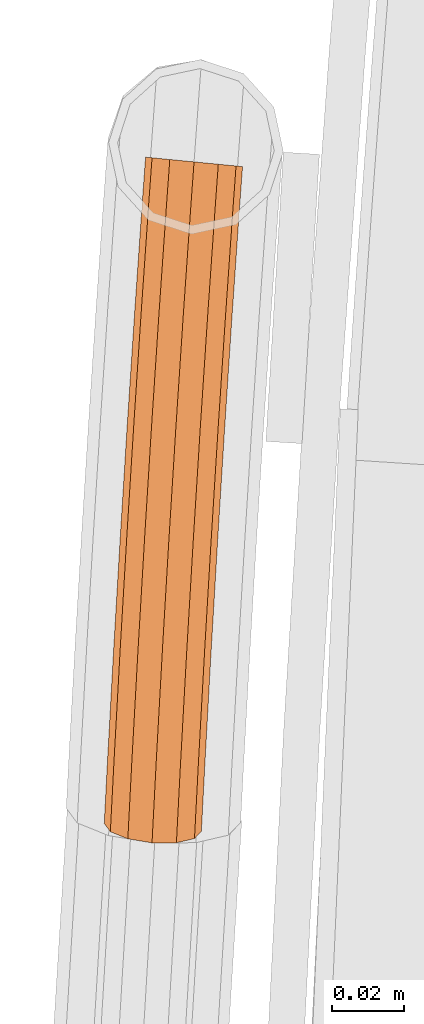
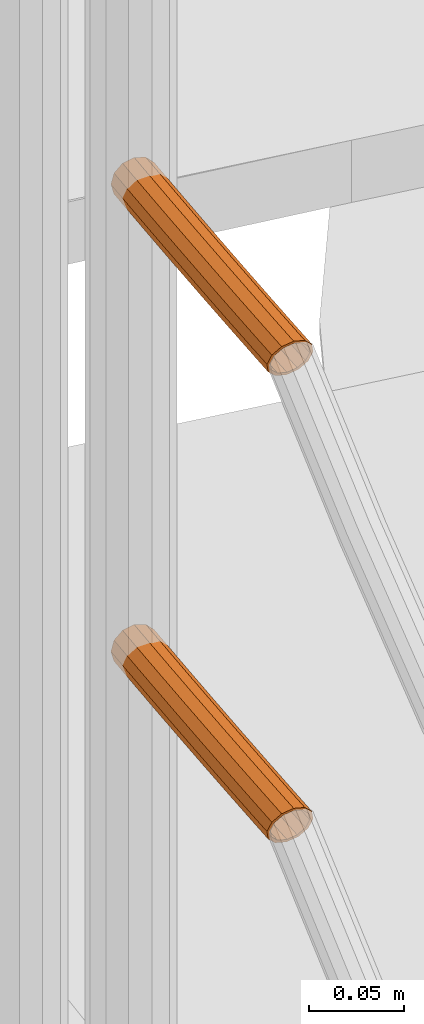
# One storey, part 57 of 126: 2 proxies.
"""IFC2X3 building model written with IfcOpenShell, lengths in millimetres."""

from ifc_helpers import new_model, si_unit, origin, origin_with_axes, place, context, project, spatial, faceted_brep, material, element, save


model = new_model("IFC2X3")

# Units and contexts
context_of_model_1 = context(None, 3, precision=0.1, world=origin())
context_of_model_2 = context(None, 3, precision=0.1, world=origin())
ifc_project = project(units=[si_unit("LENGTHUNIT", "METRE", prefix="MILLI"), si_unit("AREAUNIT", "SQUARE_METRE", prefix="CENTI"), si_unit("VOLUMEUNIT", "CUBIC_METRE", prefix="CENTI"), si_unit("MASSUNIT", "GRAM", prefix="KILO")], contexts=[context_of_model_1, context_of_model_2])

# Site, building, storey
site_placement = place(None, origin_with_axes())
site = spatial("IfcSite", under=ifc_project, at=site_placement, CompositionType="ELEMENT")
building_placement = place(site_placement, origin_with_axes())
building = spatial("IfcBuilding", under=site, at=building_placement, CompositionType="ELEMENT")
storey_placement = place(building_placement, origin_with_axes())
storey = spatial("IfcBuildingStorey", under=building, at=storey_placement, CompositionType="ELEMENT")

# Proxies
ifc_material = material(Name="S235JRG2")
proxy_1_placement = place(storey_placement, origin_with_axes())
element("IfcBuildingElementProxy", 1, at=proxy_1_placement, inside=storey, material=ifc_material, context=context_of_model_2, shape_type="Brep", body=[
    faceted_brep([(-848.952, 8648.8633, 6295.5551), (-848.1038, 8660.504, 6295.5551), (-846.3098, 8660.3291, 6288.8301), (-847.1546, 8648.7355, 6288.8301), (-841.4085, 8659.8513, 6283.907), (-842.2439, 8648.3862, 6283.907), (-834.7132, 8659.1987, 6282.1051), (-835.5359, 8647.9092, 6282.1051), (-828.018, 8658.546, 6283.907), (-828.8278, 8647.4322, 6283.907), (-823.1167, 8658.0682, 6288.8301), (-823.9172, 8647.083, 6288.8301), (-821.3227, 8657.8933, 6295.5551), (-822.1197, 8646.9551, 6295.5551), (-823.1167, 8658.0682, 6302.2801), (-823.9172, 8647.083, 6302.2801), (-828.018, 8658.546, 6307.2031), (-828.8278, 8647.4322, 6307.2031), (-834.7132, 8659.1987, 6309.0051), (-835.5359, 8647.9092, 6309.0051), (-841.4085, 8659.8513, 6307.2031), (-842.2439, 8648.3862, 6307.2031), (-846.3098, 8660.3291, 6302.2801), (-847.1546, 8648.7355, 6302.2801), (-846.957, 8648.7214, 6295.5551), (-846.1126, 8660.3099, 6295.5551), (-844.5854, 8660.161, 6301.2801), (-845.4269, 8648.6126, 6301.2801), (-840.4129, 8659.7543, 6305.4711), (-841.2465, 8648.3153, 6305.4711), (-834.7132, 8659.1987, 6307.0051), (-835.5359, 8647.9092, 6307.0051), (-829.0135, 8658.6431, 6305.4711), (-829.8253, 8647.5031, 6305.4711), (-824.8411, 8658.2363, 6301.2801), (-825.6448, 8647.2058, 6301.2801), (-823.3138, 8658.0874, 6295.5551), (-824.1147, 8647.097, 6295.5551), (-824.8411, 8658.2363, 6289.8301), (-825.6448, 8647.2058, 6289.8301), (-829.0135, 8658.6431, 6285.6391), (-829.8253, 8647.5031, 6285.6391), (-834.7132, 8659.1987, 6284.1051), (-835.5359, 8647.9092, 6284.1051), (-840.4129, 8659.7543, 6285.6391), (-841.2465, 8648.3153, 6285.6391), (-844.5854, 8660.161, 6289.8301), (-845.4269, 8648.6126, 6289.8301), (-849.2983, 8617.8278, 6288.8301), (-851.0962, 8617.9494, 6295.5551), (-844.3865, 8617.4958, 6283.907), (-837.6768, 8617.0421, 6282.1051), (-830.9671, 8616.5885, 6283.907), (-826.0553, 8616.2565, 6288.8301), (-824.2574, 8616.1349, 6295.5551), (-826.0553, 8616.2565, 6302.2801), (-830.9671, 8616.5885, 6307.2031), (-837.6768, 8617.0421, 6309.0051), (-844.3865, 8617.4958, 6307.2031), (-849.2983, 8617.8278, 6302.2801), (-847.5702, 8617.711, 6301.2801), (-849.1007, 8617.8145, 6295.5551), (-843.3888, 8617.4283, 6305.4711), (-837.6768, 8617.0421, 6307.0051), (-831.9648, 8616.656, 6305.4711), (-827.7834, 8616.3733, 6301.2801), (-826.2529, 8616.2698, 6295.5551), (-827.7834, 8616.3733, 6289.8301), (-831.9648, 8616.656, 6285.6391), (-837.6768, 8617.0421, 6284.1051), (-843.3888, 8617.4283, 6285.6391), (-847.5702, 8617.711, 6289.8301), (-851.3342, 8586.9129, 6288.8301), (-853.1324, 8587.0282, 6295.5551), (-846.4212, 8586.598, 6283.907), (-839.71, 8586.1678, 6282.1051), (-832.9987, 8585.7376, 6283.907), (-828.0858, 8585.4227, 6288.8301), (-826.2875, 8585.3074, 6295.5551), (-828.0858, 8585.4227, 6302.2801), (-832.9987, 8585.7376, 6307.2031), (-839.71, 8586.1678, 6309.0051), (-846.4212, 8586.598, 6307.2031), (-851.3342, 8586.9129, 6302.2801), (-849.6057, 8586.8021, 6301.2801), (-851.1365, 8586.9002, 6295.5551), (-845.4233, 8586.534, 6305.4711), (-839.71, 8586.1678, 6307.0051), (-833.9967, 8585.8016, 6305.4711), (-829.8143, 8585.5335, 6301.2801), (-828.2834, 8585.4353, 6295.5551), (-829.8143, 8585.5335, 6289.8301), (-833.9967, 8585.8016, 6285.6391), (-839.71, 8586.1678, 6284.1051), (-845.4233, 8586.534, 6285.6391), (-849.6057, 8586.8021, 6289.8301), (-853.2621, 8555.9911, 6288.8301), (-855.0607, 8556.1, 6295.5551), (-848.3481, 8555.6933, 6283.907), (-841.6354, 8555.2865, 6282.1051), (-834.9227, 8554.8798, 6283.907), (-830.0086, 8554.582, 6288.8301), (-828.21, 8554.473, 6295.5551), (-830.0086, 8554.582, 6302.2801), (-834.9227, 8554.8798, 6307.2031), (-841.6354, 8555.2865, 6309.0051), (-848.3481, 8555.6933, 6307.2031), (-853.2621, 8555.9911, 6302.2801), (-851.5332, 8555.8863, 6301.2801), (-853.0644, 8555.9791, 6295.5551), (-847.3499, 8555.6328, 6305.4711), (-841.6354, 8555.2865, 6307.0051), (-835.9208, 8554.9402, 6305.4711), (-831.7375, 8554.6867, 6301.2801), (-830.2063, 8554.594, 6295.5551), (-831.7375, 8554.6867, 6289.8301), (-835.9208, 8554.9402, 6285.6391), (-841.6354, 8555.2865, 6284.1051), (-847.3499, 8555.6328, 6285.6391), (-851.5332, 8555.8863, 6289.8301), (-855.0821, 8525.0627, 6288.8301), (-856.8811, 8525.1654, 6295.5551), (-850.167, 8524.7821, 6283.907), (-843.4529, 8524.3987, 6282.1051), (-836.7389, 8524.0154, 6283.907), (-831.8238, 8523.7348, 6288.8301), (-830.0248, 8523.6321, 6295.5551), (-831.8238, 8523.7348, 6302.2801), (-836.7389, 8524.0154, 6307.2031), (-843.4529, 8524.3987, 6309.0051), (-850.167, 8524.7821, 6307.2031), (-855.0821, 8525.0627, 6302.2801), (-853.3528, 8524.9639, 6301.2801), (-854.8843, 8525.0514, 6295.5551), (-849.1686, 8524.7251, 6305.4711), (-843.4529, 8524.3987, 6307.0051), (-837.7372, 8524.0724, 6305.4711), (-833.553, 8523.8335, 6301.2801), (-832.0215, 8523.7461, 6295.5551), (-833.553, 8523.8335, 6289.8301), (-837.7372, 8524.0724, 6285.6391), (-843.4529, 8524.3987, 6284.1051), (-849.1686, 8524.7251, 6285.6391), (-853.3528, 8524.9639, 6289.8301), (-856.794, 8494.1281, 6288.8301), (-858.5934, 8494.2245, 6295.5551), (-851.8781, 8493.8647, 6283.907), (-845.1627, 8493.5048, 6282.1051), (-838.4473, 8493.1449, 6283.907), (-833.5313, 8492.8814, 6288.8301), (-831.7319, 8492.785, 6295.5551), (-833.5313, 8492.8814, 6302.2801), (-838.4473, 8493.1449, 6307.2031), (-845.1627, 8493.5048, 6309.0051), (-851.8781, 8493.8647, 6307.2031), (-856.794, 8494.1281, 6302.2801), (-855.0645, 8494.0354, 6301.2801), (-856.5963, 8494.1175, 6295.5551), (-850.8795, 8493.8111, 6305.4711), (-845.1627, 8493.5048, 6307.0051), (-839.4459, 8493.1984, 6305.4711), (-835.2609, 8492.9741, 6301.2801), (-833.7291, 8492.892, 6295.5551), (-835.2609, 8492.9741, 6289.8301), (-839.4459, 8493.1984, 6285.6391), (-845.1627, 8493.5048, 6284.1051), (-850.8795, 8493.8111, 6285.6391), (-855.0645, 8494.0354, 6289.8301), (-857.6032, 8478.5199, 6288.8301), (-859.5102, 8476.5397, 6295.5551), (-852.6135, 8479.6775, 6283.907), (-845.8782, 8479.7025, 6282.1051), (-839.202, 8478.5881, 6283.907), (-834.3737, 8476.633, 6288.8301), (-832.6871, 8474.3609, 6295.5551), (-834.5941, 8472.3808, 6302.2801), (-839.5838, 8471.2232, 6307.2031), (-846.3191, 8471.1982, 6309.0051), (-852.9954, 8472.3126, 6307.2031), (-857.8236, 8474.2677, 6302.2801), (-856.0802, 8474.4436, 6301.2801), (-857.516, 8476.3777, 6295.5551), (-851.9698, 8472.7791, 6305.4711), (-846.2863, 8471.8305, 6307.0051), (-840.5525, 8471.8517, 6305.4711), (-836.3048, 8472.8372, 6301.2801), (-834.6814, 8474.5229, 6295.5551), (-836.1172, 8476.4571, 6289.8301), (-840.2275, 8478.1215, 6285.6391), (-845.911, 8479.0702, 6284.1051), (-851.6448, 8479.0489, 6285.6391), (-855.8925, 8478.0634, 6289.8301)], [[[0, 1, 2, 3]], [[3, 2, 4, 5]], [[5, 4, 6, 7]], [[7, 6, 8, 9]], [[9, 8, 10, 11]], [[11, 10, 12, 13]], [[13, 12, 14, 15]], [[15, 14, 16, 17]], [[17, 16, 18, 19]], [[19, 18, 20, 21]], [[21, 20, 22, 23]], [[0, 23, 22, 1]], [[24, 25, 26, 27]], [[27, 26, 28, 29]], [[29, 28, 30, 31]], [[31, 30, 32, 33]], [[33, 32, 34, 35]], [[35, 34, 36, 37]], [[37, 36, 38, 39]], [[39, 38, 40, 41]], [[41, 40, 42, 43]], [[43, 42, 44, 45]], [[45, 44, 46, 47]], [[24, 47, 46, 25]], [[0, 3, 48, 49]], [[3, 5, 50, 48]], [[5, 7, 51, 50]], [[7, 9, 52, 51]], [[9, 11, 53, 52]], [[11, 13, 54, 53]], [[13, 15, 55, 54]], [[15, 17, 56, 55]], [[17, 19, 57, 56]], [[19, 21, 58, 57]], [[21, 23, 59, 58]], [[23, 0, 49, 59]], [[24, 27, 60, 61]], [[27, 29, 62, 60]], [[29, 31, 63, 62]], [[31, 33, 64, 63]], [[33, 35, 65, 64]], [[35, 37, 66, 65]], [[37, 39, 67, 66]], [[39, 41, 68, 67]], [[41, 43, 69, 68]], [[43, 45, 70, 69]], [[45, 47, 71, 70]], [[47, 24, 61, 71]], [[49, 48, 72, 73]], [[48, 50, 74, 72]], [[50, 51, 75, 74]], [[51, 52, 76, 75]], [[52, 53, 77, 76]], [[53, 54, 78, 77]], [[54, 55, 79, 78]], [[55, 56, 80, 79]], [[56, 57, 81, 80]], [[57, 58, 82, 81]], [[58, 59, 83, 82]], [[59, 49, 73, 83]], [[61, 60, 84, 85]], [[60, 62, 86, 84]], [[62, 63, 87, 86]], [[63, 64, 88, 87]], [[64, 65, 89, 88]], [[65, 66, 90, 89]], [[66, 67, 91, 90]], [[67, 68, 92, 91]], [[68, 69, 93, 92]], [[69, 70, 94, 93]], [[70, 71, 95, 94]], [[71, 61, 85, 95]], [[73, 72, 96, 97]], [[72, 74, 98, 96]], [[74, 75, 99, 98]], [[75, 76, 100, 99]], [[76, 77, 101, 100]], [[77, 78, 102, 101]], [[78, 79, 103, 102]], [[79, 80, 104, 103]], [[80, 81, 105, 104]], [[81, 82, 106, 105]], [[82, 83, 107, 106]], [[83, 73, 97, 107]], [[85, 84, 108, 109]], [[84, 86, 110, 108]], [[86, 87, 111, 110]], [[87, 88, 112, 111]], [[88, 89, 113, 112]], [[89, 90, 114, 113]], [[90, 91, 115, 114]], [[91, 92, 116, 115]], [[92, 93, 117, 116]], [[93, 94, 118, 117]], [[94, 95, 119, 118]], [[95, 85, 109, 119]], [[97, 96, 120, 121]], [[96, 98, 122, 120]], [[98, 99, 123, 122]], [[99, 100, 124, 123]], [[100, 101, 125, 124]], [[101, 102, 126, 125]], [[102, 103, 127, 126]], [[103, 104, 128, 127]], [[104, 105, 129, 128]], [[105, 106, 130, 129]], [[106, 107, 131, 130]], [[107, 97, 121, 131]], [[109, 108, 132, 133]], [[108, 110, 134, 132]], [[110, 111, 135, 134]], [[111, 112, 136, 135]], [[112, 113, 137, 136]], [[113, 114, 138, 137]], [[114, 115, 139, 138]], [[115, 116, 140, 139]], [[116, 117, 141, 140]], [[117, 118, 142, 141]], [[118, 119, 143, 142]], [[119, 109, 133, 143]], [[121, 120, 144, 145]], [[120, 122, 146, 144]], [[122, 123, 147, 146]], [[123, 124, 148, 147]], [[124, 125, 149, 148]], [[125, 126, 150, 149]], [[126, 127, 151, 150]], [[127, 128, 152, 151]], [[128, 129, 153, 152]], [[129, 130, 154, 153]], [[130, 131, 155, 154]], [[131, 121, 145, 155]], [[133, 132, 156, 157]], [[132, 134, 158, 156]], [[134, 135, 159, 158]], [[135, 136, 160, 159]], [[136, 137, 161, 160]], [[137, 138, 162, 161]], [[138, 139, 163, 162]], [[139, 140, 164, 163]], [[140, 141, 165, 164]], [[141, 142, 166, 165]], [[142, 143, 167, 166]], [[143, 133, 157, 167]], [[144, 168, 169, 145]], [[144, 146, 170, 168]], [[146, 147, 171, 170]], [[147, 148, 172, 171]], [[148, 149, 173, 172]], [[149, 150, 174, 173]], [[150, 151, 175, 174]], [[151, 152, 176, 175]], [[152, 153, 177, 176]], [[153, 154, 178, 177]], [[154, 155, 179, 178]], [[145, 169, 179, 155]], [[156, 180, 181, 157]], [[156, 158, 182, 180]], [[158, 159, 183, 182]], [[159, 160, 184, 183]], [[160, 161, 185, 184]], [[161, 162, 186, 185]], [[162, 163, 187, 186]], [[163, 164, 188, 187]], [[164, 165, 189, 188]], [[165, 166, 190, 189]], [[166, 167, 191, 190]], [[157, 181, 191, 167]], [[6, 4, 2, 1, 22, 20, 18, 16, 14, 12, 10, 8], [26, 25, 46, 44, 42, 40, 38, 36, 34, 32, 30, 28]], [[177, 178, 179, 169, 168, 170, 171, 172, 173, 174, 175, 176], [180, 182, 183, 184, 185, 186, 187, 188, 189, 190, 191, 181]]]),
])
proxy_2_placement = place(storey_placement, origin_with_axes())
element("IfcBuildingElementProxy", 2, at=proxy_2_placement, inside=storey, material=ifc_material, context=context_of_model_2, shape_type="Brep", body=[
    faceted_brep([(-848.952, 8648.8633, 5995.5551), (-848.1038, 8660.504, 5995.5551), (-846.3098, 8660.3291, 5988.8301), (-847.1546, 8648.7355, 5988.8301), (-841.4085, 8659.8513, 5983.907), (-842.2439, 8648.3862, 5983.907), (-834.7132, 8659.1987, 5982.1051), (-835.5359, 8647.9092, 5982.1051), (-828.018, 8658.546, 5983.907), (-828.8278, 8647.4322, 5983.907), (-823.1167, 8658.0682, 5988.8301), (-823.9172, 8647.083, 5988.8301), (-821.3227, 8657.8933, 5995.5551), (-822.1197, 8646.9551, 5995.5551), (-823.1167, 8658.0682, 6002.2801), (-823.9172, 8647.083, 6002.2801), (-828.018, 8658.546, 6007.2031), (-828.8278, 8647.4322, 6007.2031), (-834.7132, 8659.1987, 6009.0051), (-835.5359, 8647.9092, 6009.0051), (-841.4085, 8659.8513, 6007.2031), (-842.2439, 8648.3862, 6007.2031), (-846.3098, 8660.3291, 6002.2801), (-847.1546, 8648.7355, 6002.2801), (-846.957, 8648.7214, 5995.5551), (-846.1126, 8660.3099, 5995.5551), (-844.5854, 8660.161, 6001.2801), (-845.4269, 8648.6126, 6001.2801), (-840.4129, 8659.7543, 6005.4711), (-841.2465, 8648.3153, 6005.4711), (-834.7132, 8659.1987, 6007.0051), (-835.5359, 8647.9092, 6007.0051), (-829.0135, 8658.6431, 6005.4711), (-829.8253, 8647.5031, 6005.4711), (-824.8411, 8658.2363, 6001.2801), (-825.6448, 8647.2058, 6001.2801), (-823.3138, 8658.0874, 5995.5551), (-824.1147, 8647.097, 5995.5551), (-824.8411, 8658.2363, 5989.8301), (-825.6448, 8647.2058, 5989.8301), (-829.0135, 8658.6431, 5985.6391), (-829.8253, 8647.5031, 5985.6391), (-834.7132, 8659.1987, 5984.1051), (-835.5359, 8647.9092, 5984.1051), (-840.4129, 8659.7543, 5985.6391), (-841.2465, 8648.3153, 5985.6391), (-844.5854, 8660.161, 5989.8301), (-845.4269, 8648.6126, 5989.8301), (-849.2983, 8617.8278, 5988.8301), (-851.0962, 8617.9494, 5995.5551), (-844.3865, 8617.4958, 5983.907), (-837.6768, 8617.0421, 5982.1051), (-830.9671, 8616.5885, 5983.907), (-826.0553, 8616.2565, 5988.8301), (-824.2574, 8616.1349, 5995.5551), (-826.0553, 8616.2565, 6002.2801), (-830.9671, 8616.5885, 6007.2031), (-837.6768, 8617.0421, 6009.0051), (-844.3865, 8617.4958, 6007.2031), (-849.2983, 8617.8278, 6002.2801), (-847.5702, 8617.711, 6001.2801), (-849.1007, 8617.8145, 5995.5551), (-843.3888, 8617.4283, 6005.4711), (-837.6768, 8617.0421, 6007.0051), (-831.9648, 8616.656, 6005.4711), (-827.7834, 8616.3733, 6001.2801), (-826.2529, 8616.2698, 5995.5551), (-827.7834, 8616.3733, 5989.8301), (-831.9648, 8616.656, 5985.6391), (-837.6768, 8617.0421, 5984.1051), (-843.3888, 8617.4283, 5985.6391), (-847.5702, 8617.711, 5989.8301), (-851.3342, 8586.9129, 5988.8301), (-853.1324, 8587.0282, 5995.5551), (-846.4212, 8586.598, 5983.907), (-839.71, 8586.1678, 5982.1051), (-832.9987, 8585.7376, 5983.907), (-828.0858, 8585.4227, 5988.8301), (-826.2875, 8585.3074, 5995.5551), (-828.0858, 8585.4227, 6002.2801), (-832.9987, 8585.7376, 6007.2031), (-839.71, 8586.1678, 6009.0051), (-846.4212, 8586.598, 6007.2031), (-851.3342, 8586.9129, 6002.2801), (-849.6057, 8586.8021, 6001.2801), (-851.1365, 8586.9002, 5995.5551), (-845.4233, 8586.534, 6005.4711), (-839.71, 8586.1678, 6007.0051), (-833.9967, 8585.8016, 6005.4711), (-829.8143, 8585.5335, 6001.2801), (-828.2834, 8585.4353, 5995.5551), (-829.8143, 8585.5335, 5989.8301), (-833.9967, 8585.8016, 5985.6391), (-839.71, 8586.1678, 5984.1051), (-845.4233, 8586.534, 5985.6391), (-849.6057, 8586.8021, 5989.8301), (-853.2621, 8555.9911, 5988.8301), (-855.0607, 8556.1, 5995.5551), (-848.3481, 8555.6933, 5983.907), (-841.6354, 8555.2865, 5982.1051), (-834.9227, 8554.8798, 5983.907), (-830.0086, 8554.582, 5988.8301), (-828.21, 8554.473, 5995.5551), (-830.0086, 8554.582, 6002.2801), (-834.9227, 8554.8798, 6007.2031), (-841.6354, 8555.2865, 6009.0051), (-848.3481, 8555.6933, 6007.2031), (-853.2621, 8555.9911, 6002.2801), (-851.5332, 8555.8863, 6001.2801), (-853.0644, 8555.9791, 5995.5551), (-847.3499, 8555.6328, 6005.4711), (-841.6354, 8555.2865, 6007.0051), (-835.9208, 8554.9402, 6005.4711), (-831.7375, 8554.6867, 6001.2801), (-830.2063, 8554.594, 5995.5551), (-831.7375, 8554.6867, 5989.8301), (-835.9208, 8554.9402, 5985.6391), (-841.6354, 8555.2865, 5984.1051), (-847.3499, 8555.6328, 5985.6391), (-851.5332, 8555.8863, 5989.8301), (-855.0821, 8525.0627, 5988.8301), (-856.8811, 8525.1654, 5995.5551), (-850.167, 8524.7821, 5983.907), (-843.4529, 8524.3987, 5982.1051), (-836.7389, 8524.0154, 5983.907), (-831.8238, 8523.7348, 5988.8301), (-830.0248, 8523.6321, 5995.5551), (-831.8238, 8523.7348, 6002.2801), (-836.7389, 8524.0154, 6007.2031), (-843.4529, 8524.3987, 6009.0051), (-850.167, 8524.7821, 6007.2031), (-855.0821, 8525.0627, 6002.2801), (-853.3528, 8524.9639, 6001.2801), (-854.8843, 8525.0514, 5995.5551), (-849.1686, 8524.7251, 6005.4711), (-843.4529, 8524.3987, 6007.0051), (-837.7372, 8524.0724, 6005.4711), (-833.553, 8523.8335, 6001.2801), (-832.0215, 8523.7461, 5995.5551), (-833.553, 8523.8335, 5989.8301), (-837.7372, 8524.0724, 5985.6391), (-843.4529, 8524.3987, 5984.1051), (-849.1686, 8524.7251, 5985.6391), (-853.3528, 8524.9639, 5989.8301), (-856.794, 8494.1281, 5988.8301), (-858.5934, 8494.2245, 5995.5551), (-851.8781, 8493.8647, 5983.907), (-845.1627, 8493.5048, 5982.1051), (-838.4473, 8493.1449, 5983.907), (-833.5313, 8492.8814, 5988.8301), (-831.7319, 8492.785, 5995.5551), (-833.5313, 8492.8814, 6002.2801), (-838.4473, 8493.1449, 6007.2031), (-845.1627, 8493.5048, 6009.0051), (-851.8781, 8493.8647, 6007.2031), (-856.794, 8494.1281, 6002.2801), (-855.0645, 8494.0354, 6001.2801), (-856.5963, 8494.1175, 5995.5551), (-850.8795, 8493.8111, 6005.4711), (-845.1627, 8493.5048, 6007.0051), (-839.4459, 8493.1984, 6005.4711), (-835.2609, 8492.9741, 6001.2801), (-833.7291, 8492.892, 5995.5551), (-835.2609, 8492.9741, 5989.8301), (-839.4459, 8493.1984, 5985.6391), (-845.1627, 8493.5048, 5984.1051), (-850.8795, 8493.8111, 5985.6391), (-855.0645, 8494.0354, 5989.8301), (-857.6032, 8478.5199, 5988.8301), (-859.5102, 8476.5397, 5995.5551), (-852.6135, 8479.6775, 5983.907), (-845.8782, 8479.7025, 5982.1051), (-839.202, 8478.5881, 5983.907), (-834.3737, 8476.633, 5988.8301), (-832.6871, 8474.3609, 5995.5551), (-834.5941, 8472.3808, 6002.2801), (-839.5838, 8471.2232, 6007.2031), (-846.3191, 8471.1982, 6009.0051), (-852.9954, 8472.3125, 6007.2031), (-857.8236, 8474.2677, 6002.2801), (-856.0802, 8474.4436, 6001.2801), (-857.516, 8476.3777, 5995.5551), (-851.9698, 8472.7791, 6005.4711), (-846.2863, 8471.8305, 6007.0051), (-840.5525, 8471.8517, 6005.4711), (-836.3048, 8472.8372, 6001.2801), (-834.6814, 8474.5229, 5995.5551), (-836.1172, 8476.4571, 5989.8301), (-840.2275, 8478.1215, 5985.6391), (-845.911, 8479.0702, 5984.1051), (-851.6448, 8479.0489, 5985.6391), (-855.8925, 8478.0634, 5989.8301)], [[[0, 1, 2, 3]], [[3, 2, 4, 5]], [[5, 4, 6, 7]], [[7, 6, 8, 9]], [[9, 8, 10, 11]], [[11, 10, 12, 13]], [[13, 12, 14, 15]], [[15, 14, 16, 17]], [[17, 16, 18, 19]], [[19, 18, 20, 21]], [[21, 20, 22, 23]], [[0, 23, 22, 1]], [[24, 25, 26, 27]], [[27, 26, 28, 29]], [[29, 28, 30, 31]], [[31, 30, 32, 33]], [[33, 32, 34, 35]], [[35, 34, 36, 37]], [[37, 36, 38, 39]], [[39, 38, 40, 41]], [[41, 40, 42, 43]], [[43, 42, 44, 45]], [[45, 44, 46, 47]], [[24, 47, 46, 25]], [[0, 3, 48, 49]], [[3, 5, 50, 48]], [[5, 7, 51, 50]], [[7, 9, 52, 51]], [[9, 11, 53, 52]], [[11, 13, 54, 53]], [[13, 15, 55, 54]], [[15, 17, 56, 55]], [[17, 19, 57, 56]], [[19, 21, 58, 57]], [[21, 23, 59, 58]], [[23, 0, 49, 59]], [[24, 27, 60, 61]], [[27, 29, 62, 60]], [[29, 31, 63, 62]], [[31, 33, 64, 63]], [[33, 35, 65, 64]], [[35, 37, 66, 65]], [[37, 39, 67, 66]], [[39, 41, 68, 67]], [[41, 43, 69, 68]], [[43, 45, 70, 69]], [[45, 47, 71, 70]], [[47, 24, 61, 71]], [[49, 48, 72, 73]], [[48, 50, 74, 72]], [[50, 51, 75, 74]], [[51, 52, 76, 75]], [[52, 53, 77, 76]], [[53, 54, 78, 77]], [[54, 55, 79, 78]], [[55, 56, 80, 79]], [[56, 57, 81, 80]], [[57, 58, 82, 81]], [[58, 59, 83, 82]], [[59, 49, 73, 83]], [[61, 60, 84, 85]], [[60, 62, 86, 84]], [[62, 63, 87, 86]], [[63, 64, 88, 87]], [[64, 65, 89, 88]], [[65, 66, 90, 89]], [[66, 67, 91, 90]], [[67, 68, 92, 91]], [[68, 69, 93, 92]], [[69, 70, 94, 93]], [[70, 71, 95, 94]], [[71, 61, 85, 95]], [[73, 72, 96, 97]], [[72, 74, 98, 96]], [[74, 75, 99, 98]], [[75, 76, 100, 99]], [[76, 77, 101, 100]], [[77, 78, 102, 101]], [[78, 79, 103, 102]], [[79, 80, 104, 103]], [[80, 81, 105, 104]], [[81, 82, 106, 105]], [[82, 83, 107, 106]], [[83, 73, 97, 107]], [[85, 84, 108, 109]], [[84, 86, 110, 108]], [[86, 87, 111, 110]], [[87, 88, 112, 111]], [[88, 89, 113, 112]], [[89, 90, 114, 113]], [[90, 91, 115, 114]], [[91, 92, 116, 115]], [[92, 93, 117, 116]], [[93, 94, 118, 117]], [[94, 95, 119, 118]], [[95, 85, 109, 119]], [[97, 96, 120, 121]], [[96, 98, 122, 120]], [[98, 99, 123, 122]], [[99, 100, 124, 123]], [[100, 101, 125, 124]], [[101, 102, 126, 125]], [[102, 103, 127, 126]], [[103, 104, 128, 127]], [[104, 105, 129, 128]], [[105, 106, 130, 129]], [[106, 107, 131, 130]], [[107, 97, 121, 131]], [[109, 108, 132, 133]], [[108, 110, 134, 132]], [[110, 111, 135, 134]], [[111, 112, 136, 135]], [[112, 113, 137, 136]], [[113, 114, 138, 137]], [[114, 115, 139, 138]], [[115, 116, 140, 139]], [[116, 117, 141, 140]], [[117, 118, 142, 141]], [[118, 119, 143, 142]], [[119, 109, 133, 143]], [[121, 120, 144, 145]], [[120, 122, 146, 144]], [[122, 123, 147, 146]], [[123, 124, 148, 147]], [[124, 125, 149, 148]], [[125, 126, 150, 149]], [[126, 127, 151, 150]], [[127, 128, 152, 151]], [[128, 129, 153, 152]], [[129, 130, 154, 153]], [[130, 131, 155, 154]], [[131, 121, 145, 155]], [[133, 132, 156, 157]], [[132, 134, 158, 156]], [[134, 135, 159, 158]], [[135, 136, 160, 159]], [[136, 137, 161, 160]], [[137, 138, 162, 161]], [[138, 139, 163, 162]], [[139, 140, 164, 163]], [[140, 141, 165, 164]], [[141, 142, 166, 165]], [[142, 143, 167, 166]], [[143, 133, 157, 167]], [[144, 168, 169, 145]], [[144, 146, 170, 168]], [[146, 147, 171, 170]], [[147, 148, 172, 171]], [[148, 149, 173, 172]], [[149, 150, 174, 173]], [[150, 151, 175, 174]], [[151, 152, 176, 175]], [[152, 153, 177, 176]], [[153, 154, 178, 177]], [[154, 155, 179, 178]], [[145, 169, 179, 155]], [[156, 180, 181, 157]], [[156, 158, 182, 180]], [[158, 159, 183, 182]], [[159, 160, 184, 183]], [[160, 161, 185, 184]], [[161, 162, 186, 185]], [[162, 163, 187, 186]], [[163, 164, 188, 187]], [[164, 165, 189, 188]], [[165, 166, 190, 189]], [[166, 167, 191, 190]], [[157, 181, 191, 167]], [[6, 4, 2, 1, 22, 20, 18, 16, 14, 12, 10, 8], [26, 25, 46, 44, 42, 40, 38, 36, 34, 32, 30, 28]], [[177, 178, 179, 169, 168, 170, 171, 172, 173, 174, 175, 176], [180, 182, 183, 184, 185, 186, 187, 188, 189, 190, 191, 181]]]),
])

save(model, "model.ifc")
